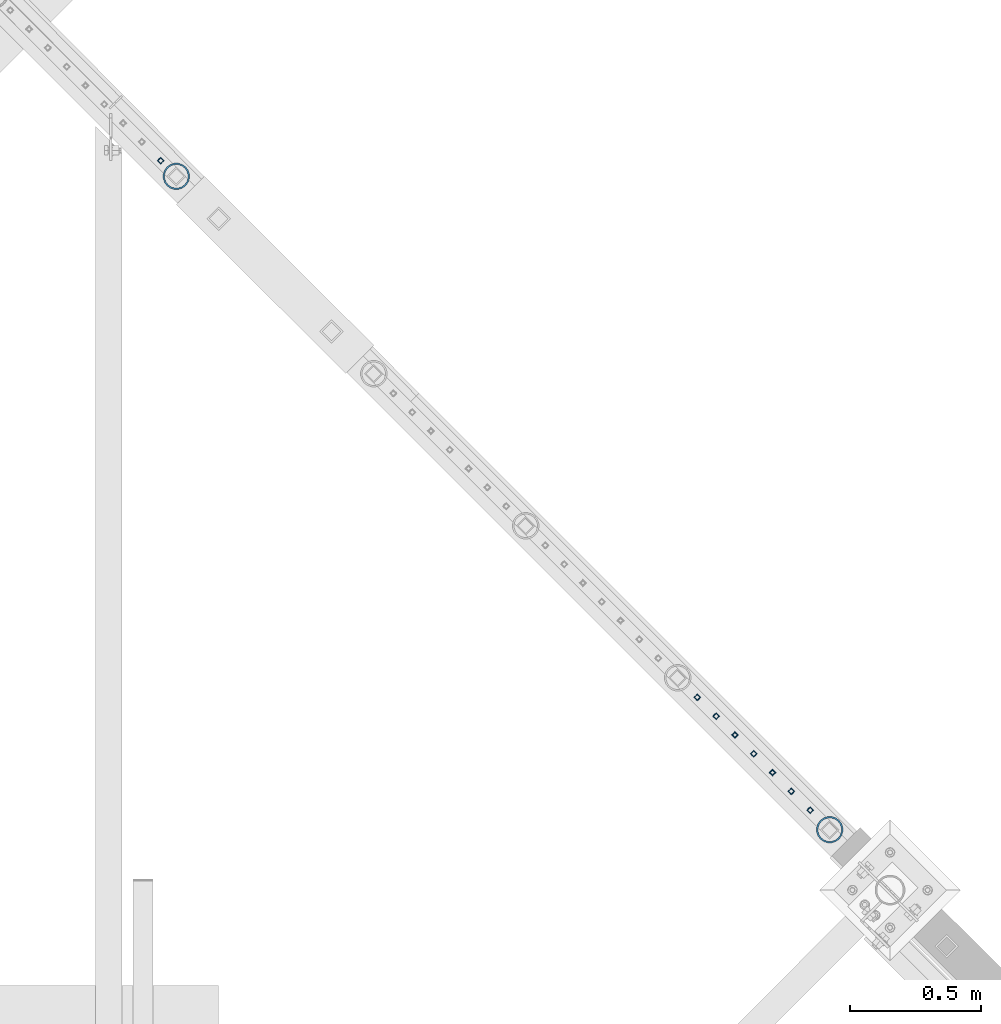
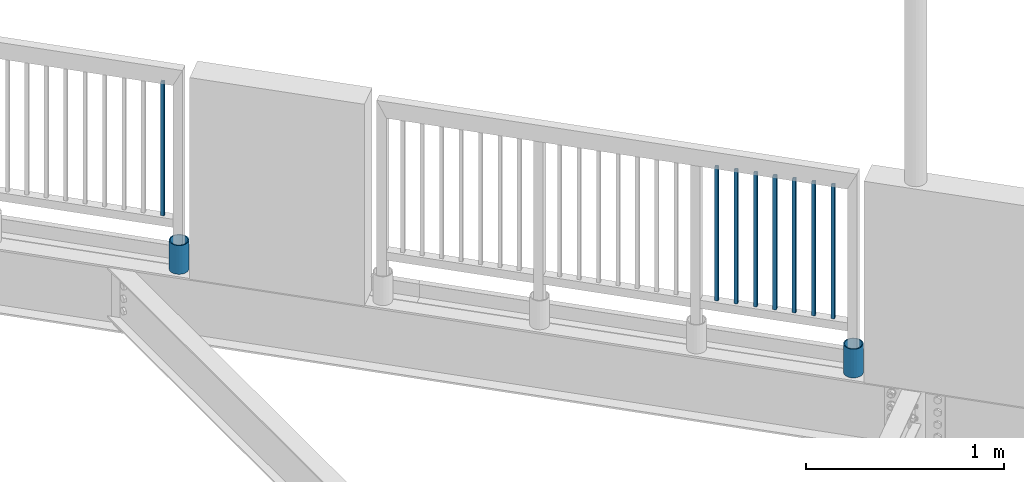
# One storey, part 251 of 975: 10 columns.
"""IFC2X3 building model written with IfcOpenShell, lengths in millimetres."""

from ifc_helpers import new_model, si_unit, frame, origin_with_axes, place, context, subcontext, project, spatial, faceted_brep, material, type_object, element, save


model = new_model("IFC2X3")

# Units and contexts
model_context = context("Model", 3, precision=1e-05, world=origin_with_axes())
body_context = subcontext(model_context, "Body", "Model", "MODEL_VIEW")
ifc_project = project(units=[si_unit("LENGTHUNIT", "METRE", prefix="MILLI"), si_unit("AREAUNIT", "SQUARE_METRE"), si_unit("VOLUMEUNIT", "CUBIC_METRE"), si_unit("MASSUNIT", "GRAM", prefix="KILO"), si_unit("TIMEUNIT", "SECOND"), si_unit("PLANEANGLEUNIT", "RADIAN"), si_unit("SOLIDANGLEUNIT", "STERADIAN"), si_unit("THERMODYNAMICTEMPERATUREUNIT", "DEGREE_CELSIUS"), si_unit("LUMINOUSINTENSITYUNIT", "LUMEN")], contexts=[model_context])

# Site, building, storey
site_placement = place(None, origin_with_axes())
site = spatial("IfcSite", under=ifc_project, at=site_placement, CompositionType="ELEMENT")
building_placement = place(site_placement, origin_with_axes())
building = spatial("IfcBuilding", under=site, at=building_placement, Name="Undefined", CompositionType="ELEMENT")
storey_placement = place(building_placement, origin_with_axes())
storey = spatial("IfcBuildingStorey", under=building, at=storey_placement, Name="Undefined", CompositionType="ELEMENT", Elevation=0.0)

# Columns
ifc_material_1 = material()
column_type_1 = type_object("IfcColumnType", Name="HSS3/4X3/4X.120_TUBES", PredefinedType="NOTDEFINED")
for number, where, z_axis, x_axis, name in (
    (1, (23768.9821548513, 24865.8885701219, 4254.49996006912), (-0.707106781186601, 0.707106781186494, 2.36468622460961e-14), (0.0, 0.0, 1.0), "PICKET"),
    (2, (25819.4671681025, 22815.2877052691, 4254.49907423335), (-0.707106781186601, 0.707106781186494, 2.36468622460961e-14), (0.0, 0.0, 1.0), "PICKET"),
    (3, (25891.3015431025, 22743.4533302691, 4254.49907423335), (-0.707106781186601, 0.707106781186494, 2.36468622460961e-14), (0.0, 0.0, 1.0), "PICKET"),
    (4, (25963.1359181025, 22671.6189552692, 4254.49907423335), (-0.707106781186601, 0.707106781186494, 2.36468622460961e-14), (0.0, 0.0, 1.0), "PICKET"),
    (5, (26034.9702931025, 22599.7845802691, 4254.49907423335), (-0.707106781186601, 0.707106781186494, 2.36468622460961e-14), (0.0, 0.0, 1.0), "PICKET"),
    (6, (26106.8046681025, 22527.9502052691, 4254.49907423335), (-0.707106781186601, 0.707106781186494, 2.36468622460961e-14), (0.0, 0.0, 1.0), "PICKET"),
    (7, (26178.6390431025, 22456.1158302691, 4254.49907423335), (-0.707106781186601, 0.707106781186494, 2.36468622460961e-14), (0.0, 0.0, 1.0), "PICKET"),
    (8, (26250.4734181025, 22384.2814552691, 4254.49907423335), (-0.707106781186601, 0.707106781186494, 2.36468622460961e-14), (0.0, 0.0, 1.0), "PICKET"),
):
    element("IfcColumn", number, at=place(storey_placement, frame(where, z_axis=z_axis, x_axis=x_axis)), inside=storey, type_object=column_type_1, material=ifc_material_1, Name=name, ObjectType="HSS3/4X3/4X.120_TUBES", context=body_context, shape_type="Brep", body=[
        faceted_brep([(0.0, 6.34999999998763, -6.34999999998763), (0.0, -6.35000000000582, -6.34999999998763), (825.49997943247, -6.35000000000582, -6.34999999998763), (825.49997943247, 6.34999999998763, -6.34999999998763), (0.0, -6.34999999998763, 6.34999999998763), (825.49997943247, -6.34999999998763, 6.34999999998763), (0.0, 6.35000000000946, 6.34999999998763), (825.49997943247, 6.35000000000946, 6.34999999998763), (0.0, 9.52499999997963, -9.52499999997963), (0.0, 9.52500000000873, 9.5249999999869), (825.49997943247, 9.52500000000873, 9.5249999999869), (825.49997943247, 9.52499999997963, -9.52499999997963), (0.0, -9.52499999997963, 9.52499999998327), (825.49997943247, -9.52499999997963, 9.52499999998327), (0.0, -9.52500000000873, -9.5249999999869), (825.49997943247, -9.52500000000873, -9.5249999999869)], [[[0, 1, 2, 3]], [[1, 4, 5, 2]], [[4, 6, 7, 5]], [[6, 0, 3, 7]], [[8, 9, 10, 11]], [[9, 12, 13, 10]], [[12, 14, 15, 13]], [[14, 8, 11, 15]], [[13, 15, 11, 10], [5, 7, 3, 2]], [[14, 12, 9, 8], [6, 4, 1, 0]]]),
    ])
ifc_material_2 = material(Name="STEEL/A53")
column_type_2 = type_object("IfcColumnType", Name="PIPE3-1/2STD", PredefinedType="NOTDEFINED")
column_1_placement = place(storey_placement, frame((23828.7588873162, 24806.0289250881, 3937.0), z_axis=(-0.707106781186601, 0.707106781186494, 2.36468622460961e-14), x_axis=(0.0, 0.0, 1.0)))
element("IfcColumn", 9, at=column_1_placement, inside=storey, type_object=column_type_2, material=ifc_material_2, ObjectType="PIPE3-1/2STD", context=body_context, shape_type="Brep", body=[
    faceted_brep([(0.0, -45.0595999999932, 1.45519152283669e-11), (0.0, -42.8542262016344, 13.924182159768), (177.8, -42.8542262016344, 13.924182159768), (177.8, -45.0595999999932, 1.45519152283669e-11), (0.0, -36.45398215971, 26.4853683542424), (177.8, -36.45398215971, 26.4853683542424), (0.0, -26.4853683541623, 36.45398215979), (177.8, -26.4853683541623, 36.45398215979), (0.0, -13.9241821596988, 42.8542262017108), (177.8, -13.9241821596988, 42.8542262017108), (0.0, 3.63797880709171e-11, 45.0596000000514), (177.8, 3.63797880709171e-11, 45.0596000000514), (0.0, 13.9241821597716, 42.8542262017036), (177.8, 13.9241821597716, 42.8542262017036), (0.0, 26.4853683542242, 36.4539821597718), (177.8, 26.4853683542242, 36.4539821597718), (0.0, 36.4539821597537, 26.4853683542206), (177.8, 36.4539821597537, 26.4853683542206), (0.0, 42.8542262016563, 13.9241821597425), (177.8, 42.8542262016563, 13.9241821597425), (0.0, 45.0595999999932, -1.09139364212751e-11), (177.8, 45.0595999999932, -1.09139364212751e-11), (0.0, 42.8542262016344, -13.9241821597643), (177.8, 42.8542262016344, -13.9241821597643), (0.0, 36.45398215971, -26.4853683542387), (177.8, 36.45398215971, -26.4853683542387), (0.0, 26.4853683541623, -36.4539821597864), (177.8, 26.4853683541623, -36.4539821597864), (0.0, 13.9241821596988, -42.8542262017072), (177.8, 13.9241821596988, -42.8542262017072), (0.0, -3.63797880709171e-11, -45.0596000000478), (177.8, -3.63797880709171e-11, -45.0596000000478), (0.0, -13.9241821597716, -42.8542262016963), (177.8, -13.9241821597716, -42.8542262016963), (0.0, -26.4853683542242, -36.4539821597682), (177.8, -26.4853683542242, -36.4539821597682), (0.0, -36.4539821597537, -26.4853683542169), (177.8, -36.4539821597537, -26.4853683542169), (0.0, -42.8542262016563, -13.9241821597352), (177.8, -42.8542262016563, -13.9241821597352), (0.0, -50.799999999992, 1.81898940354586e-11), (0.0, -48.3136710278013, -15.6980633142484), (177.8, -48.3136710278013, -15.6980633142484), (177.8, -50.799999999992, 1.81898940354586e-11), (0.0, -41.0980633142644, -29.8594908164741), (177.8, -41.0980633142644, -29.8594908164741), (0.0, -29.859490816485, -41.0980633142826), (177.8, -29.859490816485, -41.0980633142826), (0.0, -15.6980633142848, -48.313671027845), (177.8, -15.6980633142848, -48.313671027845), (0.0, -4.36557456851006e-11, -50.8000000000575), (177.8, -4.36557456851006e-11, -50.8000000000575), (0.0, 15.6980633142011, -48.3136710278523), (177.8, 15.6980633142011, -48.3136710278523), (0.0, 29.8594908164159, -41.0980633143045), (177.8, 29.8594908164159, -41.0980633143045), (0.0, 41.0980633142135, -29.8594908165032), (177.8, 41.0980633142135, -29.8594908165032), (0.0, 48.3136710277722, -15.6980633142775), (177.8, 48.3136710277722, -15.6980633142775), (0.0, 50.799999999992, -1.45519152283669e-11), (177.8, 50.799999999992, -1.45519152283669e-11), (0.0, 48.313671027794, 15.6980633142521), (177.8, 48.313671027794, 15.6980633142521), (0.0, 41.0980633142644, 29.8594908164814), (177.8, 41.0980633142644, 29.8594908164814), (0.0, 29.859490816485, 41.0980633142863), (177.8, 29.859490816485, 41.0980633142863), (0.0, 15.6980633142848, 48.3136710278486), (177.8, 15.6980633142848, 48.3136710278486), (0.0, 4.00177668780088e-11, 50.8000000000611), (177.8, 4.00177668780088e-11, 50.8000000000611), (0.0, -15.6980633142011, 48.3136710278559), (177.8, -15.6980633142011, 48.3136710278559), (0.0, -29.8594908164159, 41.0980633143081), (177.8, -29.8594908164159, 41.0980633143081), (0.0, -41.0980633142171, 29.8594908165069), (177.8, -41.0980633142171, 29.8594908165069), (0.0, -48.3136710277722, 15.6980633142812), (177.8, -48.3136710277722, 15.6980633142812)], [[[0, 1, 2, 3]], [[1, 4, 5, 2]], [[4, 6, 7, 5]], [[6, 8, 9, 7]], [[8, 10, 11, 9]], [[10, 12, 13, 11]], [[12, 14, 15, 13]], [[14, 16, 17, 15]], [[16, 18, 19, 17]], [[18, 20, 21, 19]], [[20, 22, 23, 21]], [[22, 24, 25, 23]], [[24, 26, 27, 25]], [[26, 28, 29, 27]], [[28, 30, 31, 29]], [[30, 32, 33, 31]], [[32, 34, 35, 33]], [[34, 36, 37, 35]], [[36, 38, 39, 37]], [[38, 0, 3, 39]], [[40, 41, 42, 43]], [[41, 44, 45, 42]], [[44, 46, 47, 45]], [[46, 48, 49, 47]], [[48, 50, 51, 49]], [[50, 52, 53, 51]], [[52, 54, 55, 53]], [[54, 56, 57, 55]], [[56, 58, 59, 57]], [[58, 60, 61, 59]], [[60, 62, 63, 61]], [[62, 64, 65, 63]], [[64, 66, 67, 65]], [[66, 68, 69, 67]], [[68, 70, 71, 69]], [[70, 72, 73, 71]], [[72, 74, 75, 73]], [[74, 76, 77, 75]], [[76, 78, 79, 77]], [[78, 40, 43, 79]], [[45, 47, 49, 51, 53, 55, 57, 59, 61, 63, 65, 67, 69, 71, 73, 75, 77, 79, 43, 42], [5, 7, 9, 11, 13, 15, 17, 19, 21, 23, 25, 27, 29, 31, 33, 35, 37, 39, 3, 2]], [[78, 76, 74, 72, 70, 68, 66, 64, 62, 60, 58, 56, 54, 52, 50, 48, 46, 44, 41, 40], [38, 36, 34, 32, 30, 28, 26, 24, 22, 20, 18, 16, 14, 12, 10, 8, 6, 4, 1, 0]]]),
])
column_2_placement = place(storey_placement, frame((26325.3274108574, 22309.5801974972, 3937.0), z_axis=(-0.707106781186601, 0.707106781186494, 2.36468622460961e-14), x_axis=(0.0, 0.0, 1.0)))
element("IfcColumn", 10, at=column_2_placement, inside=storey, type_object=column_type_2, material=ifc_material_2, ObjectType="PIPE3-1/2STD", context=body_context, shape_type="Brep", body=[
    faceted_brep([(0.0, -45.0595999999932, 1.45519152283669e-11), (0.0, -42.8542262016344, 13.924182159768), (177.8, -42.8542262016344, 13.924182159768), (177.8, -45.0595999999932, 1.45519152283669e-11), (0.0, -36.45398215971, 26.4853683542424), (177.8, -36.45398215971, 26.4853683542424), (0.0, -26.4853683541623, 36.45398215979), (177.8, -26.4853683541623, 36.45398215979), (0.0, -13.9241821596988, 42.8542262017108), (177.8, -13.9241821596988, 42.8542262017108), (0.0, 3.63797880709171e-11, 45.0596000000514), (177.8, 3.63797880709171e-11, 45.0596000000514), (0.0, 13.9241821597716, 42.8542262017036), (177.8, 13.9241821597716, 42.8542262017036), (0.0, 26.4853683542242, 36.4539821597718), (177.8, 26.4853683542242, 36.4539821597718), (0.0, 36.4539821597537, 26.4853683542206), (177.8, 36.4539821597537, 26.4853683542206), (0.0, 42.8542262016563, 13.9241821597425), (177.8, 42.8542262016563, 13.9241821597425), (0.0, 45.0595999999932, -1.09139364212751e-11), (177.8, 45.0595999999932, -1.09139364212751e-11), (0.0, 42.8542262016344, -13.9241821597643), (177.8, 42.8542262016344, -13.9241821597643), (0.0, 36.45398215971, -26.4853683542387), (177.8, 36.45398215971, -26.4853683542387), (0.0, 26.4853683541623, -36.4539821597864), (177.8, 26.4853683541623, -36.4539821597864), (0.0, 13.9241821596988, -42.8542262017072), (177.8, 13.9241821596988, -42.8542262017072), (0.0, -3.63797880709171e-11, -45.0596000000478), (177.8, -3.63797880709171e-11, -45.0596000000478), (0.0, -13.9241821597716, -42.8542262016963), (177.8, -13.9241821597716, -42.8542262016963), (0.0, -26.4853683542242, -36.4539821597682), (177.8, -26.4853683542242, -36.4539821597682), (0.0, -36.4539821597537, -26.4853683542169), (177.8, -36.4539821597537, -26.4853683542169), (0.0, -42.8542262016563, -13.9241821597352), (177.8, -42.8542262016563, -13.9241821597352), (0.0, -50.799999999992, 1.81898940354586e-11), (0.0, -48.3136710278013, -15.6980633142484), (177.8, -48.3136710278013, -15.6980633142484), (177.8, -50.799999999992, 1.81898940354586e-11), (0.0, -41.0980633142644, -29.8594908164741), (177.8, -41.0980633142644, -29.8594908164741), (0.0, -29.859490816485, -41.0980633142826), (177.8, -29.859490816485, -41.0980633142826), (0.0, -15.6980633142848, -48.313671027845), (177.8, -15.6980633142848, -48.313671027845), (0.0, -4.36557456851006e-11, -50.8000000000575), (177.8, -4.36557456851006e-11, -50.8000000000575), (0.0, 15.6980633142011, -48.3136710278523), (177.8, 15.6980633142011, -48.3136710278523), (0.0, 29.8594908164159, -41.0980633143045), (177.8, 29.8594908164159, -41.0980633143045), (0.0, 41.0980633142135, -29.8594908165032), (177.8, 41.0980633142135, -29.8594908165032), (0.0, 48.3136710277722, -15.6980633142775), (177.8, 48.3136710277722, -15.6980633142775), (0.0, 50.799999999992, -1.45519152283669e-11), (177.8, 50.799999999992, -1.45519152283669e-11), (0.0, 48.313671027794, 15.6980633142521), (177.8, 48.313671027794, 15.6980633142521), (0.0, 41.0980633142644, 29.8594908164814), (177.8, 41.0980633142644, 29.8594908164814), (0.0, 29.859490816485, 41.0980633142863), (177.8, 29.859490816485, 41.0980633142863), (0.0, 15.6980633142848, 48.3136710278486), (177.8, 15.6980633142848, 48.3136710278486), (0.0, 4.00177668780088e-11, 50.8000000000611), (177.8, 4.00177668780088e-11, 50.8000000000611), (0.0, -15.6980633142011, 48.3136710278559), (177.8, -15.6980633142011, 48.3136710278559), (0.0, -29.8594908164159, 41.0980633143081), (177.8, -29.8594908164159, 41.0980633143081), (0.0, -41.0980633142171, 29.8594908165069), (177.8, -41.0980633142171, 29.8594908165069), (0.0, -48.3136710277722, 15.6980633142812), (177.8, -48.3136710277722, 15.6980633142812)], [[[0, 1, 2, 3]], [[1, 4, 5, 2]], [[4, 6, 7, 5]], [[6, 8, 9, 7]], [[8, 10, 11, 9]], [[10, 12, 13, 11]], [[12, 14, 15, 13]], [[14, 16, 17, 15]], [[16, 18, 19, 17]], [[18, 20, 21, 19]], [[20, 22, 23, 21]], [[22, 24, 25, 23]], [[24, 26, 27, 25]], [[26, 28, 29, 27]], [[28, 30, 31, 29]], [[30, 32, 33, 31]], [[32, 34, 35, 33]], [[34, 36, 37, 35]], [[36, 38, 39, 37]], [[38, 0, 3, 39]], [[40, 41, 42, 43]], [[41, 44, 45, 42]], [[44, 46, 47, 45]], [[46, 48, 49, 47]], [[48, 50, 51, 49]], [[50, 52, 53, 51]], [[52, 54, 55, 53]], [[54, 56, 57, 55]], [[56, 58, 59, 57]], [[58, 60, 61, 59]], [[60, 62, 63, 61]], [[62, 64, 65, 63]], [[64, 66, 67, 65]], [[66, 68, 69, 67]], [[68, 70, 71, 69]], [[70, 72, 73, 71]], [[72, 74, 75, 73]], [[74, 76, 77, 75]], [[76, 78, 79, 77]], [[78, 40, 43, 79]], [[45, 47, 49, 51, 53, 55, 57, 59, 61, 63, 65, 67, 69, 71, 73, 75, 77, 79, 43, 42], [5, 7, 9, 11, 13, 15, 17, 19, 21, 23, 25, 27, 29, 31, 33, 35, 37, 39, 3, 2]], [[78, 76, 74, 72, 70, 68, 66, 64, 62, 60, 58, 56, 54, 52, 50, 48, 46, 44, 41, 40], [38, 36, 34, 32, 30, 28, 26, 24, 22, 20, 18, 16, 14, 12, 10, 8, 6, 4, 1, 0]]]),
])

save(model, "model.ifc")
